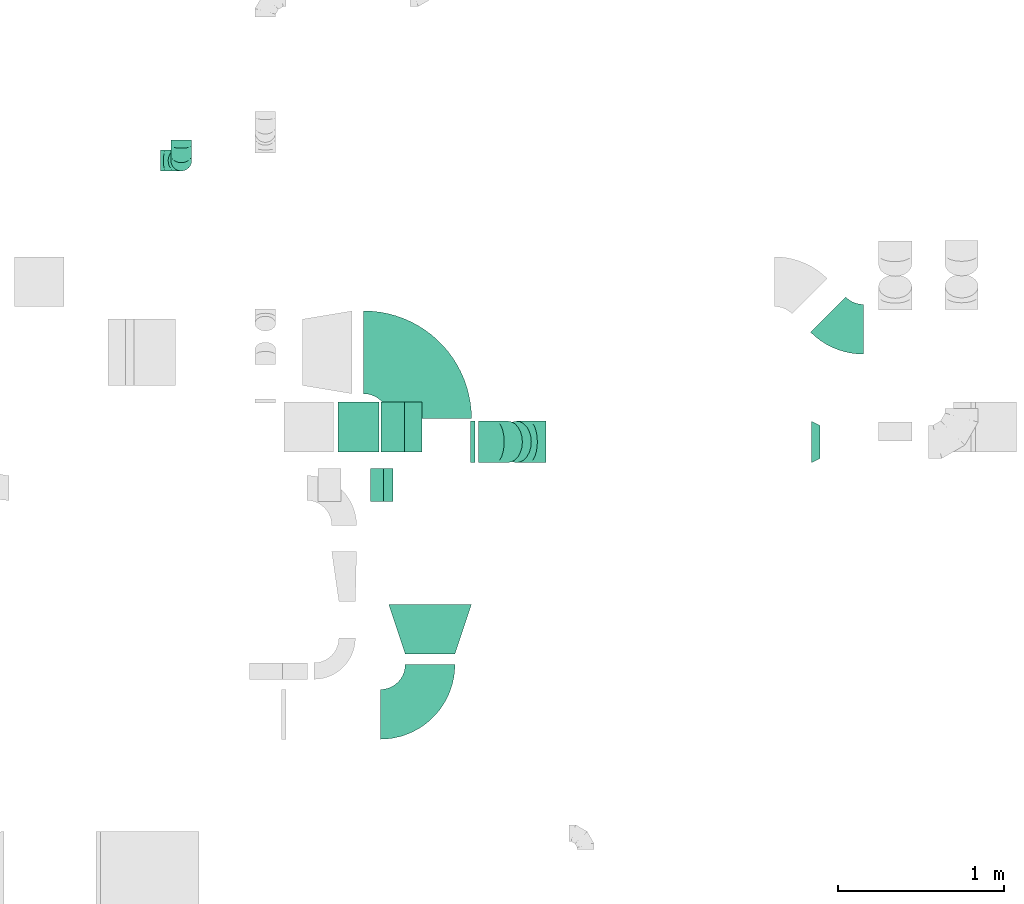
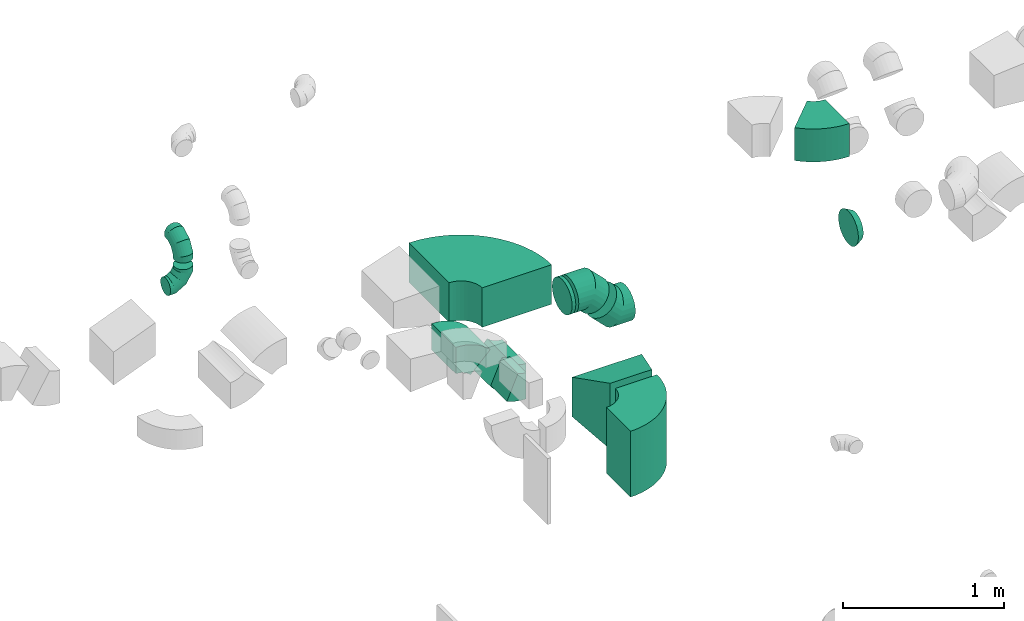
# One storey, part 27 of 44: 13 flow fittings.
"""IFC2X3 building model written with IfcOpenShell, lengths in millimetres."""

from ifc_helpers import new_model, entity, si_unit, converted_unit, derived_unit, direction, frame, frame_2d, origin, place, context, subcontext, project, spatial, polyline, circle_curve, parameter, trimmed, segment, composite_curve, outline, extrude, faceted_brep, source, transform, mapped, material, type_object, type_shapes, element, save


model = new_model("IFC2X3")

# Units and contexts
model_context = context("Model", 3, precision=0.01, world=origin(), true_north=direction((6.12303176911189e-17, 1.0)))
body_context = subcontext(model_context, "Body", "Model", "MODEL_VIEW")
ifc_project = project(units=[si_unit("LENGTHUNIT", "METRE", prefix="MILLI"), si_unit("AREAUNIT", "SQUARE_METRE"), si_unit("VOLUMEUNIT", "CUBIC_METRE"), converted_unit("PLANEANGLEUNIT", "DEGREE", entity("IfcRatioMeasure", 0.0174532925199433), si_unit("PLANEANGLEUNIT", "RADIAN"), dimensions=[0, 0, 0, 0, 0, 0, 0]), si_unit("MASSUNIT", "GRAM", prefix="KILO"), derived_unit("MASSDENSITYUNIT", [(si_unit("MASSUNIT", "GRAM", prefix="KILO"), 1), (si_unit("LENGTHUNIT", "METRE"), -3)]), derived_unit("MOMENTOFINERTIAUNIT", [(si_unit("LENGTHUNIT", "METRE"), 4)]), si_unit("TIMEUNIT", "SECOND"), si_unit("FREQUENCYUNIT", "HERTZ"), si_unit("THERMODYNAMICTEMPERATUREUNIT", "DEGREE_CELSIUS"), derived_unit("THERMALTRANSMITTANCEUNIT", [(si_unit("MASSUNIT", "GRAM", prefix="KILO"), 1), (si_unit("THERMODYNAMICTEMPERATUREUNIT", "KELVIN"), -1), (si_unit("TIMEUNIT", "SECOND"), -3)]), derived_unit("VOLUMETRICFLOWRATEUNIT", [(si_unit("LENGTHUNIT", "METRE"), 3), (si_unit("TIMEUNIT", "SECOND"), -1)]), derived_unit("MASSFLOWRATEUNIT", [(si_unit("MASSUNIT", "GRAM", prefix="KILO"), 1), (si_unit("TIMEUNIT", "SECOND"), -1)]), derived_unit("ROTATIONALFREQUENCYUNIT", [(si_unit("TIMEUNIT", "SECOND"), -1)]), si_unit("ELECTRICCURRENTUNIT", "AMPERE"), si_unit("ELECTRICVOLTAGEUNIT", "VOLT"), si_unit("POWERUNIT", "WATT"), si_unit("FORCEUNIT", "NEWTON", prefix="KILO"), si_unit("ILLUMINANCEUNIT", "LUX"), si_unit("LUMINOUSFLUXUNIT", "LUMEN"), si_unit("LUMINOUSINTENSITYUNIT", "CANDELA"), derived_unit("USERDEFINED", [(si_unit("MASSUNIT", "GRAM", prefix="KILO"), -1), (si_unit("LENGTHUNIT", "METRE"), -2), (si_unit("TIMEUNIT", "SECOND"), 3), (si_unit("LUMINOUSFLUXUNIT", "LUMEN"), 1)]), derived_unit("LINEARVELOCITYUNIT", [(si_unit("LENGTHUNIT", "METRE"), 1), (si_unit("TIMEUNIT", "SECOND"), -1)]), si_unit("PRESSUREUNIT", "PASCAL"), derived_unit("USERDEFINED", [(si_unit("LENGTHUNIT", "METRE"), -2), (si_unit("MASSUNIT", "GRAM", prefix="KILO"), 1), (si_unit("TIMEUNIT", "SECOND"), -2)]), derived_unit("LINEARFORCEUNIT", [(si_unit("MASSUNIT", "GRAM", prefix="KILO"), 1), (si_unit("LENGTHUNIT", "METRE"), 1), (si_unit("TIMEUNIT", "SECOND"), -2), (si_unit("LENGTHUNIT", "METRE"), -1)]), derived_unit("PLANARFORCEUNIT", [(si_unit("MASSUNIT", "GRAM", prefix="KILO"), 1), (si_unit("LENGTHUNIT", "METRE"), 1), (si_unit("TIMEUNIT", "SECOND"), -2), (si_unit("LENGTHUNIT", "METRE"), -2)])], contexts=[model_context])

# Site, building, storey
site_placement = place(None, origin())
site = spatial("IfcSite", under=ifc_project, at=site_placement, CompositionType="ELEMENT")
building_placement = place(site_placement, origin())
building = spatial("IfcBuilding", under=site, at=building_placement, CompositionType="ELEMENT")
storey_placement = place(building_placement, frame((0.0, 0.0, 15900.0)))
storey = spatial("IfcBuildingStorey", under=building, at=storey_placement, CompositionType="ELEMENT", Elevation=15900.0)

# Flow fittings
ifc_material = material()
duct_fitting_type_1 = type_object("IfcDuctFittingType", PredefinedType="NOTDEFINED", material=ifc_material)
shared_shape_1 = source(origin(), body_context, "Body", "Brep", [
    faceted_brep([(20.0, 0.0, -125.0), (20.0, 32.35, -120.74), (20.0, 62.5, -108.25), (20.0, 88.39, -88.39), (20.0, 108.25, -62.5), (20.0, 120.74, -32.35), (20.0, 125.0, 0.0), (20.0, 120.74, 32.35), (20.0, 108.25, 62.5), (20.0, 88.39, 88.39), (20.0, 62.5, 108.25), (20.0, 32.35, 120.74), (20.0, 0.0, 125.0), (20.0, -32.35, 120.74), (20.0, -62.5, 108.25), (20.0, -88.39, 88.39), (20.0, -108.25, 62.5), (20.0, -120.74, 32.35), (20.0, -125.0, 0.0), (20.0, -120.74, -32.35), (20.0, -108.25, -62.5), (20.0, -88.39, -88.39), (20.0, -62.5, -108.25), (20.0, -32.35, -120.74), (0.0, 0.0, 125.0), (-6.1, 0.0, 125.0), (-6.1, -32.35, 120.74), (0.0, -32.35, 120.74), (-6.1, -62.5, 108.25), (0.0, -62.5, 108.25), (0.0, -88.39, 88.39), (-6.1, -88.39, 88.39), (0.0, -108.25, 62.5), (-6.1, -108.25, 62.5), (-6.1, -120.74, 32.35), (0.0, -120.74, 32.35), (-6.1, -125.0, 0.0), (0.0, -125.0, 0.0), (-6.1, -120.74, -32.35), (0.0, -120.74, -32.35), (-6.1, -108.25, -62.5), (0.0, -108.25, -62.5), (0.0, -88.39, -88.39), (-6.1, -88.39, -88.39), (0.0, -62.5, -108.25), (-6.1, -62.5, -108.25), (-6.1, -32.35, -120.74), (0.0, -32.35, -120.74), (-6.1, 0.0, -125.0), (0.0, 0.0, -125.0), (-6.1, 32.35, -120.74), (0.0, 32.35, -120.74), (-6.1, 62.5, -108.25), (0.0, 62.5, -108.25), (0.0, 88.39, -88.39), (-6.1, 88.39, -88.39), (0.0, 108.25, -62.5), (-6.1, 108.25, -62.5), (-6.1, 120.74, -32.35), (0.0, 120.74, -32.35), (-6.1, 125.0, 0.0), (0.0, 125.0, 0.0), (-6.1, 120.74, 32.35), (0.0, 120.74, 32.35), (-6.1, 108.25, 62.5), (0.0, 108.25, 62.5), (0.0, 88.39, 88.39), (-6.1, 88.39, 88.39), (0.0, 62.5, 108.25), (-6.1, 62.5, 108.25), (-6.1, 32.35, 120.74), (0.0, 32.35, 120.74)], [[[0, 1, 2, 3, 4, 5, 6, 7, 8, 9, 10, 11, 12, 13, 14, 15, 16, 17, 18, 19, 20, 21, 22, 23]], [[13, 12, 24, 25, 26, 27]], [[14, 13, 27, 26, 28, 29]], [[30, 15, 14, 29, 28, 31]], [[17, 16, 32, 33, 34, 35]], [[18, 17, 35, 34, 36, 37]], [[32, 16, 15, 30, 31, 33]], [[19, 18, 37, 36, 38, 39]], [[20, 19, 39, 38, 40, 41]], [[42, 21, 20, 41, 40, 43]], [[23, 22, 44, 45, 46, 47]], [[0, 23, 47, 46, 48, 49]], [[44, 22, 21, 42, 43, 45]], [[1, 0, 49, 48, 50, 51]], [[2, 1, 51, 50, 52, 53]], [[54, 3, 2, 53, 52, 55]], [[5, 4, 56, 57, 58, 59]], [[6, 5, 59, 58, 60, 61]], [[56, 4, 3, 54, 55, 57]], [[7, 6, 61, 60, 62, 63]], [[8, 7, 63, 62, 64, 65]], [[66, 9, 8, 65, 64, 67]], [[11, 10, 68, 69, 70, 71]], [[12, 11, 71, 70, 25, 24]], [[68, 10, 9, 66, 67, 69]], [[46, 45, 43, 40, 38, 36, 34, 33, 31, 28, 26, 25, 70, 69, 67, 64, 62, 60, 58, 57, 55, 52, 50, 48]]]),
])
type_shapes(duct_fitting_type_1, [shared_shape_1])
flow_fitting_1_placement = place(storey_placement, frame((53890.04, 14435.52, 3250.0), z_axis=(0.0, 0.0, -1.0), x_axis=(1.0, 0.0, 0.0)))
element("IfcFlowFitting", 1, at=flow_fitting_1_placement, inside=storey, type_object=duct_fitting_type_1, material=ifc_material, context=body_context, shape_type="MappedRepresentation", body=[
    mapped(shared_shape_1, transform((0.0, 0.0, 0.0), scale=1.0)),
])
duct_fitting_type_2 = type_object("IfcDuctFittingType", PredefinedType="NOTDEFINED", material=ifc_material)
shared_shape_2 = source(origin(), body_context, "Body", "Brep", [
    faceted_brep([(-125.0, 0.0, -62.5), (-125.0, -16.18, -60.37), (-125.0, -31.25, -54.13), (-125.0, -44.19, -44.19), (-125.0, -54.13, -31.25), (-125.0, -60.37, -16.18), (-125.0, -62.5, 0.0), (-125.0, -60.37, 16.18), (-125.0, -54.13, 31.25), (-125.0, -44.19, 44.19), (-125.0, -31.25, 54.13), (-125.0, -16.18, 60.37), (-125.0, 0.0, 62.5), (-125.0, 16.18, 60.37), (-125.0, 31.25, 54.13), (-125.0, 44.19, 44.19), (-125.0, 54.13, 31.25), (-125.0, 60.37, 16.18), (-125.0, 62.5, 0.0), (-125.0, 60.37, -16.18), (-125.0, 54.13, -31.25), (-125.0, 44.19, -44.19), (-125.0, 31.25, -54.13), (-125.0, 16.18, -60.37), (-95.84, 16.18, 60.37), (-99.88, 31.25, 54.13), (-91.51, 0.0, 62.5), (-103.35, 44.19, 44.19), (-107.68, 60.37, 16.18), (-108.25, 62.5, 0.0), (-106.01, 54.13, 31.25), (-106.01, 54.13, -31.25), (-103.35, 44.19, -44.19), (-107.68, 60.37, -16.18), (-95.84, 16.18, -60.37), (-91.51, 0.0, -62.5), (-99.88, 31.25, -54.13), (-87.17, -16.18, -60.37), (-83.13, -31.25, -54.13), (-79.66, -44.19, -44.19), (-77.0, -54.13, -31.25), (-75.33, -60.37, -16.18), (-74.76, -62.5, 0.0), (-75.33, -60.37, 16.18), (-77.0, -54.13, 31.25), (-79.66, -44.19, 44.19), (-83.13, -31.25, 54.13), (-87.17, -16.18, 60.37), (-45.34, 45.34, 60.37), (-56.37, 56.37, 54.13), (-33.49, 33.49, 62.5), (-65.85, 65.85, 44.19), (-73.12, 73.12, 31.25), (-77.69, 77.69, 16.18), (-79.25, 79.25, 0.0), (-77.69, 77.69, -16.18), (-73.12, 73.12, -31.25), (-65.85, 65.85, -44.19), (-45.34, 45.34, -60.37), (-33.49, 33.49, -62.5), (-56.37, 56.37, -54.13), (-21.65, 21.65, -60.37), (-10.62, 10.62, -54.13), (-1.14, 1.14, -44.19), (6.13, -6.13, -31.25), (10.7, -10.7, -16.18), (12.26, -12.26, 0.0), (10.7, -10.7, 16.18), (6.13, -6.13, 31.25), (-1.14, 1.14, 44.19), (-10.62, 10.62, 54.13), (-21.65, 21.65, 60.37), (-16.18, 95.84, 60.37), (-31.25, 99.88, 54.13), (0.0, 91.51, 62.5), (-44.19, 103.35, 44.19), (-54.13, 106.01, 31.25), (-60.37, 107.68, 16.18), (-62.5, 108.25, 0.0), (-60.37, 107.68, -16.18), (-54.13, 106.01, -31.25), (-44.19, 103.35, -44.19), (-16.18, 95.84, -60.37), (0.0, 91.51, -62.5), (-31.25, 99.88, -54.13), (16.18, 87.17, -60.37), (31.25, 83.13, -54.13), (44.19, 79.66, -44.19), (54.13, 77.0, -31.25), (60.37, 75.33, -16.18), (62.5, 74.76, 0.0), (60.37, 75.33, 16.18), (54.13, 77.0, 31.25), (44.19, 79.66, 44.19), (31.25, 83.13, 54.13), (16.18, 87.17, 60.37), (-16.18, 125.0, -60.37), (-31.25, 125.0, -54.13), (-44.19, 125.0, -44.19), (-54.13, 125.0, -31.25), (-60.37, 125.0, -16.18), (-62.5, 125.0, 0.0), (-60.37, 125.0, 16.18), (-54.13, 125.0, 31.25), (-44.19, 125.0, 44.19), (-31.25, 125.0, 54.13), (-16.18, 125.0, 60.37), (0.0, 125.0, 62.5), (16.18, 125.0, 60.37), (31.25, 125.0, 54.13), (44.19, 125.0, 44.19), (54.13, 125.0, 31.25), (60.37, 125.0, 16.18), (62.5, 125.0, 0.0), (60.37, 125.0, -16.18), (54.13, 125.0, -31.25), (44.19, 125.0, -44.19), (31.25, 125.0, -54.13), (16.18, 125.0, -60.37), (0.0, 125.0, -62.5)], [[[0, 1, 2, 3, 4, 5, 6, 7, 8, 9, 10, 11, 12, 13, 14, 15, 16, 17, 18, 19, 20, 21, 22, 23]], [[24, 25, 14, 13]], [[26, 24, 13, 12]], [[14, 25, 27, 15]], [[28, 29, 18, 17]], [[30, 28, 17, 16]], [[15, 27, 30, 16]], [[20, 31, 32, 21]], [[33, 31, 20, 19]], [[18, 29, 33, 19]], [[34, 35, 0, 23]], [[36, 34, 23, 22]], [[21, 32, 36, 22]], [[1, 0, 35, 37]], [[2, 1, 37, 38]], [[38, 39, 3, 2]], [[5, 4, 40, 41]], [[6, 5, 41, 42]], [[39, 40, 4, 3]], [[6, 42, 43, 7]], [[7, 43, 44, 8]], [[45, 9, 8, 44]], [[9, 45, 46, 10]], [[10, 46, 47, 11]], [[26, 12, 11, 47]], [[48, 49, 25, 24]], [[50, 48, 24, 26]], [[27, 25, 49, 51]], [[52, 53, 28, 30]], [[51, 52, 30, 27]], [[29, 28, 53, 54]], [[55, 56, 31, 33]], [[54, 55, 33, 29]], [[57, 32, 31, 56]], [[58, 59, 35, 34]], [[60, 58, 34, 36]], [[57, 60, 36, 32]], [[37, 35, 59, 61]], [[38, 37, 61, 62]], [[39, 38, 62, 63]], [[41, 40, 64, 65]], [[42, 41, 65, 66]], [[63, 64, 40, 39]], [[43, 42, 66, 67]], [[44, 43, 67, 68]], [[68, 69, 45, 44]], [[46, 45, 69, 70]], [[47, 46, 70, 71]], [[26, 47, 71, 50]], [[72, 73, 49, 48]], [[74, 72, 48, 50]], [[51, 49, 73, 75]], [[76, 77, 53, 52]], [[75, 76, 52, 51]], [[54, 53, 77, 78]], [[79, 80, 56, 55]], [[78, 79, 55, 54]], [[81, 57, 56, 80]], [[82, 83, 59, 58]], [[84, 82, 58, 60]], [[81, 84, 60, 57]], [[61, 59, 83, 85]], [[62, 61, 85, 86]], [[63, 62, 86, 87]], [[65, 64, 88, 89]], [[66, 65, 89, 90]], [[87, 88, 64, 63]], [[67, 66, 90, 91]], [[68, 67, 91, 92]], [[92, 93, 69, 68]], [[70, 69, 93, 94]], [[71, 70, 94, 95]], [[50, 71, 95, 74]], [[96, 97, 98, 99, 100, 101, 102, 103, 104, 105, 106, 107, 108, 109, 110, 111, 112, 113, 114, 115, 116, 117, 118, 119]], [[72, 74, 107, 106]], [[73, 72, 106, 105]], [[75, 73, 105, 104]], [[77, 76, 103, 102]], [[78, 77, 102, 101]], [[75, 104, 103, 76]], [[78, 101, 100, 79]], [[79, 100, 99, 80]], [[80, 99, 98, 81]], [[96, 119, 83, 82]], [[97, 96, 82, 84]], [[84, 81, 98, 97]], [[83, 119, 118, 85]], [[85, 118, 117, 86]], [[116, 87, 86, 117]], [[88, 115, 114, 89]], [[89, 114, 113, 90]], [[115, 88, 87, 116]], [[91, 90, 113, 112]], [[92, 91, 112, 111]], [[111, 110, 93, 92]], [[95, 94, 109, 108]], [[74, 95, 108, 107]], [[110, 109, 94, 93]]]),
])
type_shapes(duct_fitting_type_2, [shared_shape_2])
for number, where, z_axis, x_axis in (
    (2, (52139.95, 16131.51, 3250.0), (1.0, 0.0, 0.0), (0.0, -1.0, 0.0)),
    (3, (52139.95, 16131.51, 2950.0), (0.0, 1.0, 0.0), (0.0, 0.0, -1.0)),
):
    element("IfcFlowFitting", number, at=place(storey_placement, frame(where, z_axis=z_axis, x_axis=x_axis)), inside=storey, type_object=duct_fitting_type_2, material=ifc_material, context=body_context, shape_type="MappedRepresentation", body=[
        mapped(shared_shape_2, transform((0.0, 0.0, 0.0), scale=1.0)),
    ])
duct_fitting_type_3 = type_object("IfcDuctFittingType", PredefinedType="NOTDEFINED", material=ifc_material)
shared_shape_3 = source(origin(), body_context, "Body", "Brep", [
    faceted_brep([(-103.55, 0.0, -125.0), (-103.55, -32.35, -120.74), (-103.55, -62.5, -108.25), (-103.55, -88.39, -88.39), (-103.55, -108.25, -62.5), (-103.55, -120.74, -32.35), (-103.55, -125.0, 0.0), (-103.55, -120.74, 32.35), (-103.55, -108.25, 62.5), (-103.55, -88.39, 88.39), (-103.55, -62.5, 108.25), (-103.55, -32.35, 120.74), (-103.55, 0.0, 125.0), (-103.55, 32.35, 120.74), (-103.55, 62.5, 108.25), (-103.55, 88.39, 88.39), (-103.55, 108.25, 62.5), (-103.55, 120.74, 32.35), (-103.55, 125.0, 0.0), (-103.55, 120.74, -32.35), (-103.55, 108.25, -62.5), (-103.55, 88.39, -88.39), (-103.55, 62.5, -108.25), (-103.55, 32.35, -120.74), (-13.4, 32.35, 120.74), (-25.89, 62.5, 108.25), (0.0, 0.0, 125.0), (-36.61, 88.39, 88.39), (-44.84, 108.25, 62.5), (-50.01, 120.74, 32.35), (-51.78, 125.0, 0.0), (-50.01, 120.74, -32.35), (-44.84, 108.25, -62.5), (-36.61, 88.39, -88.39), (-13.4, 32.35, -120.74), (0.0, 0.0, -125.0), (-25.89, 62.5, -108.25), (13.4, -32.35, -120.74), (25.89, -62.5, -108.25), (36.61, -88.39, -88.39), (44.84, -108.25, -62.5), (50.01, -120.74, -32.35), (51.78, -125.0, 0.0), (50.01, -120.74, 32.35), (44.84, -108.25, 62.5), (36.61, -88.39, 88.39), (25.89, -62.5, 108.25), (13.4, -32.35, 120.74), (73.22, 73.22, 125.0), (50.35, 96.1, 120.74), (29.03, 117.42, 108.25), (10.72, 135.72, 88.39), (-3.32, 149.77, 62.5), (-12.15, 158.6, 32.35), (-15.17, 161.61, 0.0), (-12.15, 158.6, -32.35), (-3.32, 149.77, -62.5), (10.72, 135.72, -88.39), (29.03, 117.42, -108.25), (50.35, 96.1, -120.74), (73.22, 73.22, -125.0), (96.1, 50.35, -120.74), (117.42, 29.03, -108.25), (135.72, 10.72, -88.39), (149.77, -3.32, -62.5), (158.6, -12.15, -32.35), (161.61, -15.17, 0.0), (158.6, -12.15, 32.35), (149.77, -3.32, 62.5), (135.72, 10.72, 88.39), (117.42, 29.03, 108.25), (96.1, 50.35, 120.74)], [[[0, 1, 2, 3, 4, 5, 6, 7, 8, 9, 10, 11, 12, 13, 14, 15, 16, 17, 18, 19, 20, 21, 22, 23]], [[24, 25, 14, 13]], [[26, 24, 13, 12]], [[14, 25, 27, 15]], [[28, 29, 17, 16]], [[28, 16, 15, 27]], [[30, 18, 17, 29]], [[31, 32, 20, 19]], [[30, 31, 19, 18]], [[32, 33, 21, 20]], [[34, 35, 0, 23]], [[36, 34, 23, 22]], [[33, 36, 22, 21]], [[1, 0, 35, 37]], [[2, 1, 37, 38]], [[38, 39, 3, 2]], [[5, 4, 40, 41]], [[6, 5, 41, 42]], [[39, 40, 4, 3]], [[6, 42, 43, 7]], [[7, 43, 44, 8]], [[8, 44, 45, 9]], [[9, 45, 46, 10]], [[10, 46, 47, 11]], [[26, 12, 11, 47]], [[24, 26, 48, 49]], [[25, 24, 49, 50]], [[27, 25, 50, 51]], [[29, 28, 52, 53]], [[30, 29, 53, 54]], [[51, 52, 28, 27]], [[30, 54, 55, 31]], [[31, 55, 56, 32]], [[57, 33, 32, 56]], [[36, 58, 59, 34]], [[34, 59, 60, 35]], [[58, 36, 33, 57]], [[35, 60, 61, 37]], [[37, 61, 62, 38]], [[63, 39, 38, 62]], [[40, 64, 65, 41]], [[41, 65, 66, 42]], [[64, 40, 39, 63]], [[43, 42, 66, 67]], [[44, 43, 67, 68]], [[68, 69, 45, 44]], [[47, 46, 70, 71]], [[26, 47, 71, 48]], [[69, 70, 46, 45]], [[59, 58, 57, 56, 55, 54, 53, 52, 51, 50, 49, 48, 71, 70, 69, 68, 67, 66, 65, 64, 63, 62, 61, 60]]]),
])
type_shapes(duct_fitting_type_3, [shared_shape_3])
for number, where, z_axis, x_axis in (
    (4, (54235.04, 14435.52, 3050.0), (0.0, -1.0, 0.0), (0.707106781186306, 0.0, -0.707106781186789)),
    (5, (54035.04, 14435.52, 3250.0), (0.0, -1.0, 0.0), (-0.707106781186533, 0.0, 0.707106781186562)),
):
    element("IfcFlowFitting", number, at=place(storey_placement, frame(where, z_axis=z_axis, x_axis=x_axis)), inside=storey, type_object=duct_fitting_type_3, material=ifc_material, context=body_context, shape_type="MappedRepresentation", body=[
        mapped(shared_shape_3, transform((0.0, 0.0, 0.0), scale=1.0)),
    ])
duct_fitting_type_4 = type_object("IfcDuctFittingType", PredefinedType="NOTDEFINED", material=ifc_material)
shared_shape_4 = source(origin(), body_context, "Body", "Brep", [
    faceted_brep([(50.0, -73.47, -101.13), (50.0, -38.63, -118.88), (50.0, 0.0, -125.0), (50.0, 38.63, -118.88), (50.0, 73.47, -101.13), (50.0, 101.13, -73.47), (50.0, 118.88, -38.63), (50.0, 125.0, 0.0), (50.0, 118.88, 38.63), (50.0, 101.13, 73.47), (50.0, 73.47, 101.13), (50.0, 38.63, 118.88), (50.0, 0.0, 125.0), (50.0, -38.63, 118.88), (50.0, -73.47, 101.13), (50.0, -101.13, 73.47), (50.0, -118.88, 38.63), (50.0, -125.0, 0.0), (50.0, -118.88, -38.63), (50.0, -101.13, -73.47), (0.0, 30.9, -95.11), (0.0, 0.0, -100.0), (0.0, -30.9, -95.11), (0.0, -58.78, -80.9), (0.0, -80.9, -58.78), (0.0, -95.11, -30.9), (0.0, -100.0, 0.0), (0.0, -95.11, 30.9), (0.0, -80.9, 58.78), (0.0, -58.78, 80.9), (0.0, -30.9, 95.11), (0.0, 0.0, 100.0), (0.0, 30.9, 95.11), (0.0, 58.78, 80.9), (0.0, 80.9, 58.78), (0.0, 95.11, 30.9), (0.0, 100.0, 0.0), (0.0, 95.11, -30.9), (0.0, 80.9, -58.78), (0.0, 58.78, -80.9)], [[[0, 1, 2, 3, 4, 5, 6, 7, 8, 9, 10, 11, 12, 13, 14, 15, 16, 17, 18, 19]], [[20, 21, 22, 23, 24, 25, 26, 27, 28, 29, 30, 31, 32, 33, 34, 35, 36, 37, 38, 39]], [[35, 34, 9, 8]], [[36, 35, 8, 7]], [[34, 33, 10, 9]], [[10, 33, 32, 11]], [[11, 32, 31, 12]], [[30, 29, 14, 13]], [[31, 30, 13, 12]], [[29, 28, 15, 14]], [[15, 28, 27, 16]], [[16, 27, 26, 17]], [[25, 24, 19, 18]], [[26, 25, 18, 17]], [[24, 23, 0, 19]], [[0, 23, 22, 1]], [[1, 22, 21, 2]], [[20, 39, 4, 3]], [[21, 20, 3, 2]], [[39, 38, 5, 4]], [[5, 38, 37, 6]], [[6, 37, 36, 7]]]),
])
type_shapes(duct_fitting_type_4, [shared_shape_4])
flow_fitting_2_placement = place(storey_placement, frame((55990.04, 14435.52, 3050.0), z_axis=(0.0, 0.0, 1.0), x_axis=(-1.0, 0.0, 0.0)))
element("IfcFlowFitting", 6, at=flow_fitting_2_placement, inside=storey, type_object=duct_fitting_type_4, material=ifc_material, context=body_context, shape_type="MappedRepresentation", body=[
    mapped(shared_shape_4, transform((0.0, 0.0, 0.0), scale=1.0)),
])
duct_fitting_type_5 = type_object("IfcDuctFittingType", PredefinedType="NOTDEFINED", material=ifc_material)
shared_shape_5 = source(origin(), body_context, "Body", "Brep", [
    faceted_brep([(300.0, -250.0, 150.0), (300.0, -250.0, -150.0), (300.0, 250.0, -150.0), (300.0, 250.0, 150.0), (0.0, -150.0, 250.0), (0.0, 150.0, 250.0), (0.0, 150.0, -250.0), (0.0, -150.0, -250.0)], [[[0, 1, 2, 3]], [[4, 5, 6, 7]], [[4, 7, 1, 0]], [[7, 6, 2, 1]], [[6, 5, 3, 2]], [[5, 4, 0, 3]]]),
])
type_shapes(duct_fitting_type_5, [shared_shape_5])
flow_fitting_3_placement = place(storey_placement, frame((53640.04, 13156.14, 3250.0), z_axis=(0.0, 0.0, 1.0), x_axis=(0.0, 1.0, 0.0)))
element("IfcFlowFitting", 7, at=flow_fitting_3_placement, inside=storey, type_object=duct_fitting_type_5, material=ifc_material, context=body_context, shape_type="MappedRepresentation", body=[
    mapped(shared_shape_5, transform((0.0, 0.0, 0.0), scale=1.0)),
])
duct_fitting_type_6 = type_object("IfcDuctFittingType", PredefinedType="NOTDEFINED", material=ifc_material)
shared_shape_6 = source(origin(), body_context, "Body", "SweptSolid", [
    extrude(outline(composite_curve([segment(polyline([(-136.61, -88.39), (63.39, -88.39)]), True, "CONTINUOUS"), segment(trimmed(circle_curve(frame_2d((213.39, -88.39), x_axis=(-0.707106781186546, 0.707106781186546)), 150.0), [parameter(0.0)], [parameter(45.0)], True, "PARAMETER"), False, "CONTINUOUS"), segment(polyline([(107.32, 17.68), (-34.1, 159.1)]), True, "CONTINUOUS"), segment(trimmed(circle_curve(frame_2d((213.39, -88.39), x_axis=(-0.707106781186546, 0.707106781186546)), 350.0), [parameter(0.0)], [parameter(45.0)], True, "PARAMETER"), True, "CONTINUOUS")], self_intersect=False)), frame((-15.17, 36.61, -150.0), z_axis=(0.0, 0.0, 1.0), x_axis=(-0.707106781186547, 0.707106781186548, 0.0)), (0.0, 0.0, 1.0), 300.0),
])
type_shapes(duct_fitting_type_6, [shared_shape_6])
for number, where, z_axis, x_axis in (
    (8, (53189.03, 14525.32, 3075.0), (0.0, 1.0, 0.0), (1.0, 0.0, 0.0)),
    (9, (53487.02, 14525.32, 2777.01), (0.0, -1.0, 0.0), (0.707106781186487, 0.0, -0.707106781186608)),
):
    element("IfcFlowFitting", number, at=place(storey_placement, frame(where, z_axis=z_axis, x_axis=x_axis)), inside=storey, type_object=duct_fitting_type_6, material=ifc_material, context=body_context, shape_type="MappedRepresentation", body=[
        mapped(shared_shape_6, transform((0.0, 0.0, 0.0), scale=1.0)),
    ])
duct_fitting_type_7 = type_object("IfcDuctFittingType", PredefinedType="NOTDEFINED", material=ifc_material)
shared_shape_7 = source(origin(), body_context, "Body", "SweptSolid", [
    extrude(outline(composite_curve([segment(polyline([(-450.0, -200.0), (50.0, -200.0)]), True, "CONTINUOUS"), segment(trimmed(circle_curve(frame_2d((200.0, -200.0), x_axis=(0.0, 1.0)), 150.0), [parameter(0.0)], [parameter(90.0000000000001)], True, "PARAMETER"), False, "CONTINUOUS"), segment(polyline([(200.0, -50.0), (200.0, 450.0)]), True, "CONTINUOUS"), segment(trimmed(circle_curve(frame_2d((200.0, -200.0), x_axis=(0.0, 1.0)), 650.0), [parameter(0.0)], [parameter(90.0000000000001)], True, "PARAMETER"), True, "CONTINUOUS")], self_intersect=False)), frame((-200.0, 200.0, -150.0), z_axis=(0.0, 0.0, 1.0), x_axis=(-1.0, 0.0, 0.0)), (0.0, 0.0, 1.0), 300.0),
])
type_shapes(duct_fitting_type_7, [shared_shape_7])
flow_fitting_4_placement = place(storey_placement, frame((53640.04, 14975.52, 3250.0), z_axis=(0.0, 0.0, 1.0), x_axis=(0.0, 1.0, 0.0)))
element("IfcFlowFitting", 10, at=flow_fitting_4_placement, inside=storey, type_object=duct_fitting_type_7, material=ifc_material, context=body_context, shape_type="MappedRepresentation", body=[
    mapped(shared_shape_7, transform((0.0, 0.0, 0.0), scale=1.0)),
])
duct_fitting_type_8 = type_object("IfcDuctFittingType", PredefinedType="NOTDEFINED", material=ifc_material)
shared_shape_8 = source(origin(), body_context, "Body", "SweptSolid", [
    extrude(outline(composite_curve([segment(polyline([(-300.0, -150.0), (0.0, -150.0)]), True, "CONTINUOUS"), segment(trimmed(circle_curve(frame_2d((150.0, -150.0), x_axis=(0.0, 1.0)), 150.0), [parameter(0.0)], [parameter(90.0)], True, "PARAMETER"), False, "CONTINUOUS"), segment(polyline([(150.0, 0.0), (150.0, 300.0)]), True, "CONTINUOUS"), segment(trimmed(circle_curve(frame_2d((150.0, -150.0), x_axis=(0.0, 1.0)), 450.0), [parameter(0.0)], [parameter(90.0000000000001)], True, "PARAMETER"), True, "CONTINUOUS")], self_intersect=False)), frame((-150.0, 150.0, -250.0), z_axis=(0.0, 0.0, 1.0), x_axis=(-1.0, 0.0, 0.0)), (0.0, 0.0, 1.0), 500.0),
])
type_shapes(duct_fitting_type_8, [shared_shape_8])
flow_fitting_5_placement = place(storey_placement, frame((53640.04, 12792.39, 3250.0)))
element("IfcFlowFitting", 11, at=flow_fitting_5_placement, inside=storey, type_object=duct_fitting_type_8, material=ifc_material, context=body_context, shape_type="MappedRepresentation", body=[
    mapped(shared_shape_8, transform((0.0, 0.0, 0.0), scale=1.0)),
])
duct_fitting_type_9 = type_object("IfcDuctFittingType", PredefinedType="NOTDEFINED", material=ifc_material)
shared_shape_9 = source(origin(), body_context, "Body", "SweptSolid", [
    extrude(outline(composite_curve([segment(polyline([(-193.93, -106.07), (106.07, -106.07)]), True, "CONTINUOUS"), segment(trimmed(circle_curve(frame_2d((256.07, -106.07), x_axis=(-0.707106781186553, 0.707106781186553)), 150.0), [parameter(0.0)], [parameter(45.0)], True, "PARAMETER"), False, "CONTINUOUS"), segment(polyline([(150.0, 0.0), (-62.13, 212.13)]), True, "CONTINUOUS"), segment(trimmed(circle_curve(frame_2d((256.07, -106.07), x_axis=(-0.707106781186553, 0.707106781186553)), 450.0), [parameter(0.0)], [parameter(45.0)], True, "PARAMETER"), True, "CONTINUOUS")], self_intersect=False)), frame((-18.2, 43.93, -125.0), z_axis=(0.0, 0.0, 1.0), x_axis=(-0.707106781186547, 0.707106781186548, 0.0)), (0.0, 0.0, 1.0), 250.0),
])
type_shapes(duct_fitting_type_9, [shared_shape_9])
flow_fitting_6_placement = place(storey_placement, frame((56128.66, 15114.34, 3284.58), z_axis=(0.0, 0.0, 1.0), x_axis=(0.707106781186527, -0.707106781186568, 0.0)))
element("IfcFlowFitting", 12, at=flow_fitting_6_placement, inside=storey, type_object=duct_fitting_type_9, material=ifc_material, context=body_context, shape_type="MappedRepresentation", body=[
    mapped(shared_shape_9, transform((0.0, 0.0, 0.0), scale=1.0)),
])
duct_fitting_type_10 = type_object("IfcDuctFittingType", PredefinedType="NOTDEFINED", material=ifc_material)
shared_shape_10 = source(origin(), body_context, "Body", "SweptSolid", [
    extrude(outline(composite_curve([segment(polyline([(-110.16, -49.36), (89.84, -49.36)]), True, "CONTINUOUS"), segment(trimmed(circle_curve(frame_2d((239.84, -49.36), x_axis=(-0.918736047311617, 0.394872226638217)), 150.0), [parameter(0.0)], [parameter(23.2580054037017)], True, "PARAMETER"), False, "CONTINUOUS"), segment(polyline([(102.03, 9.87), (-81.72, 88.85)]), True, "CONTINUOUS"), segment(trimmed(circle_curve(frame_2d((239.84, -49.36), x_axis=(-0.918736047311617, 0.394872226638217)), 350.0), [parameter(0.0)], [parameter(23.2580054037017)], True, "PARAMETER"), True, "CONTINUOUS")], self_intersect=False)), frame((-2.09, 10.16, -100.0), z_axis=(0.0, 0.0, 1.0), x_axis=(-0.394872226638217, 0.918736047311618, 0.0)), (0.0, 0.0, 1.0), 200.0),
])
type_shapes(duct_fitting_type_10, [shared_shape_10])
flow_fitting_7_placement = place(storey_placement, frame((53366.08, 14175.53, 2950.0), z_axis=(0.0, 1.0, 0.0), x_axis=(-1.0, 0.0, 0.0)))
element("IfcFlowFitting", 13, at=flow_fitting_7_placement, inside=storey, type_object=duct_fitting_type_10, material=ifc_material, context=body_context, shape_type="MappedRepresentation", body=[
    mapped(shared_shape_10, transform((0.0, 0.0, 0.0), scale=1.0)),
])

save(model, "model.ifc")
